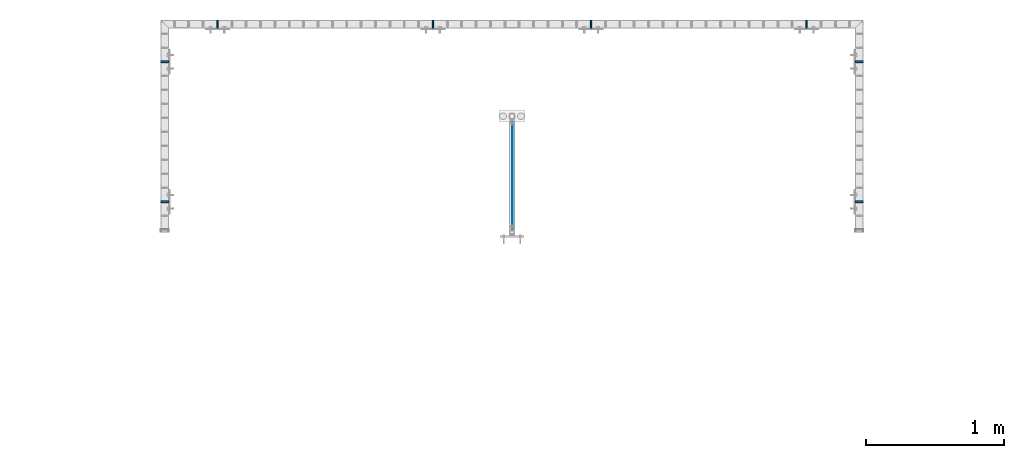
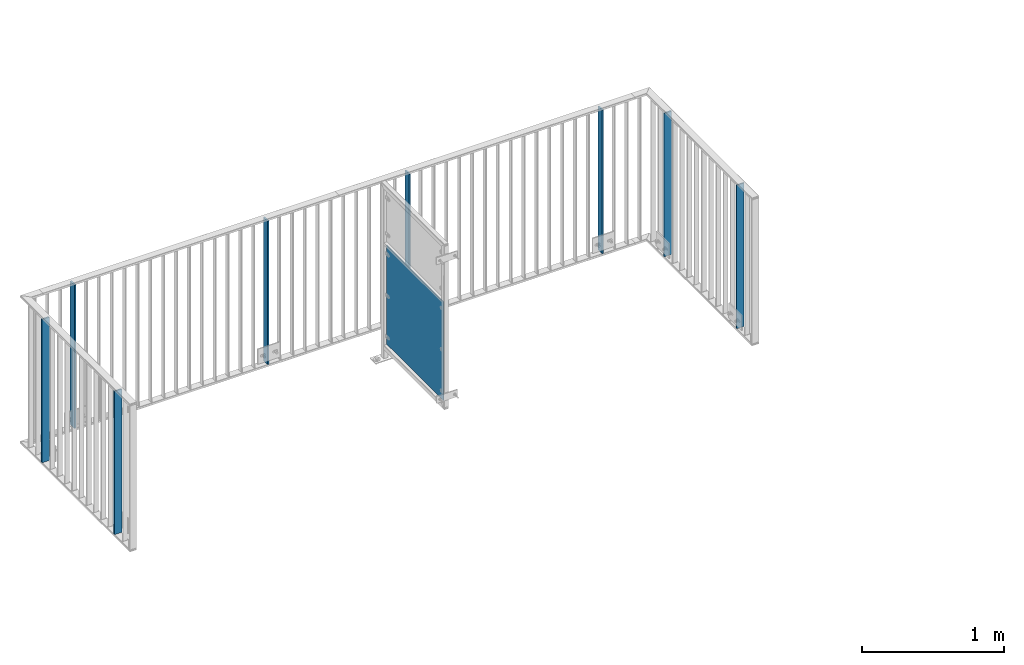
# One storey, part 40 of 156: 9 plates, 5 elements without a shape of their own.
"""IFC2X3 building model written with IfcOpenShell, lengths in millimetres."""

from ifc_helpers import new_model, si_unit, frame, origin_with_axes, origin_2d_with_axis, place, context, subcontext, project, spatial, rectangle, extrude, material, type_object, element, aggregate, save


model = new_model("IFC2X3")

# Units and contexts
model_context = context("Model", 3, precision=1e-05, world=origin_with_axes())
body_context = subcontext(model_context, "Body", "Model", "MODEL_VIEW")
ifc_project = project(units=[si_unit("LENGTHUNIT", "METRE", prefix="MILLI"), si_unit("AREAUNIT", "SQUARE_METRE"), si_unit("VOLUMEUNIT", "CUBIC_METRE"), si_unit("MASSUNIT", "GRAM", prefix="KILO"), si_unit("TIMEUNIT", "SECOND"), si_unit("PLANEANGLEUNIT", "RADIAN"), si_unit("SOLIDANGLEUNIT", "STERADIAN"), si_unit("THERMODYNAMICTEMPERATUREUNIT", "DEGREE_CELSIUS"), si_unit("LUMINOUSINTENSITYUNIT", "LUMEN")], contexts=[model_context])

# Site, building, storey
site_placement = place(None, origin_with_axes())
site = spatial("IfcSite", under=ifc_project, at=site_placement, CompositionType="ELEMENT")
building_placement = place(site_placement, origin_with_axes())
building = spatial("IfcBuilding", under=site, at=building_placement, Name="Undefined", CompositionType="ELEMENT")
storey_placement = place(building_placement, origin_with_axes())
storey = spatial("IfcBuildingStorey", under=building, at=storey_placement, Name="Undefined", CompositionType="ELEMENT", Elevation=0.0)

# Assembly, plates
assembly_1_placement = place(storey_placement, origin_with_axes())
assembly_1 = element("IfcElementAssembly", 1, at=assembly_1_placement, inside=storey, AssemblyPlace="NOTDEFINED", PredefinedType="RIGID_FRAME")
ifc_material = material(Name="STEEL/S235JR")
plate_type_1 = type_object("IfcPlateType", PredefinedType="NOTDEFINED")
plate_1_placement = place(assembly_1_placement, frame((17325.0016407503, 22766.5810137578, 3980.00000000003), z_axis=(-1.0, 0.0, 0.0), x_axis=(0.0, 0.0, -1.0)))
plate_1 = element("IfcPlate", 2, at=plate_1_placement, type_object=plate_type_1, material=ifc_material, context=body_context, shape_type="SweptSolid", body=[
    extrude(rectangle(XDim=12.0, YDim=60.0, at=origin_2d_with_axis()), frame((1230.0, 0.0, 0.0), z_axis=(-1.0, 0.0, 0.0), x_axis=(0.0, -1.0, 0.0)), (0.0, 0.0, 1.0), 1230.0),
])
plate_2_placement = place(assembly_1_placement, frame((17325.0016407503, 23784.4303835178, 3980.00000000003), z_axis=(-1.0, 0.0, 0.0), x_axis=(0.0, 0.0, -1.0)))
plate_2 = element("IfcPlate", 3, at=plate_2_placement, type_object=plate_type_1, material=ifc_material, context=body_context, shape_type="SweptSolid", body=[
    extrude(rectangle(XDim=12.0, YDim=60.0, at=origin_2d_with_axis()), frame((1230.0, 0.0, 0.0), z_axis=(-1.0, 0.0, 0.0), x_axis=(0.0, -1.0, 0.0)), (0.0, 0.0, 1.0), 1230.0),
])
aggregate(assembly_1, [plate_1, plate_2])

# Assembly, plate
assembly_2_placement = place(storey_placement, origin_with_axes())
assembly_2 = element("IfcElementAssembly", 4, at=assembly_2_placement, inside=storey, AssemblyPlace="NOTDEFINED", PredefinedType="RIGID_FRAME")
plate_3_placement = place(assembly_2_placement, frame((12274.9983592497, 22766.5810137578, 3980.00000000003), z_axis=(1.0, 0.0, 0.0), x_axis=(0.0, 0.0, -1.0)))
plate_3 = element("IfcPlate", 5, at=plate_3_placement, type_object=plate_type_1, material=ifc_material, context=body_context, shape_type="SweptSolid", body=[
    extrude(rectangle(XDim=12.0, YDim=60.0, at=origin_2d_with_axis()), frame((1230.0, 0.0, 0.0), z_axis=(-1.0, 0.0, 0.0), x_axis=(0.0, -1.0, 0.0)), (0.0, 0.0, 1.0), 1230.0),
])

assembly_3_placement = place(storey_placement, origin_with_axes())
assembly_3 = element("IfcElementAssembly", 6, at=assembly_3_placement, inside=storey, AssemblyPlace="NOTDEFINED", PredefinedType="RIGID_FRAME")
plate_4_placement = place(assembly_3_placement, frame((15374.6454415188, 24057.9916060596, 3980.00000000003), z_axis=(0.0, -1.0, 0.0), x_axis=(0.0, 0.0, -1.0)))
plate_4 = element("IfcPlate", 7, at=plate_4_placement, type_object=plate_type_1, material=ifc_material, context=body_context, shape_type="SweptSolid", body=[
    extrude(rectangle(XDim=12.0, YDim=60.0, at=origin_2d_with_axis()), frame((1230.0, 0.0, 0.0), z_axis=(-1.0, 0.0, 0.0), x_axis=(0.0, -1.0, 0.0)), (0.0, 0.0, 1.0), 1230.0),
])

# Assembly, plates
assembly_4_placement = place(storey_placement, origin_with_axes())
assembly_4 = element("IfcElementAssembly", 8, at=assembly_4_placement, inside=storey, AssemblyPlace="NOTDEFINED", PredefinedType="RIGID_FRAME")
plate_5_placement = place(assembly_4_placement, frame((14225.3401831972, 24057.9916060596, 3980.00000000003), z_axis=(0.0, -1.0, 0.0), x_axis=(0.0, 0.0, -1.0)))
plate_5 = element("IfcPlate", 9, at=plate_5_placement, type_object=plate_type_1, material=ifc_material, context=body_context, shape_type="SweptSolid", body=[
    extrude(rectangle(XDim=12.0, YDim=60.0, at=origin_2d_with_axis()), frame((1230.0, 0.0, 0.0), z_axis=(-1.0, 0.0, 0.0), x_axis=(0.0, -1.0, 0.0)), (0.0, 0.0, 1.0), 1230.0),
])
plate_6_placement = place(assembly_4_placement, frame((12658.3187312877, 24057.9916060596, 3980.00000000003), z_axis=(0.0, -1.0, 0.0), x_axis=(0.0, 0.0, -1.0)))
plate_6 = element("IfcPlate", 10, at=plate_6_placement, type_object=plate_type_1, material=ifc_material, context=body_context, shape_type="SweptSolid", body=[
    extrude(rectangle(XDim=12.0, YDim=60.0, at=origin_2d_with_axis()), frame((1230.0, 0.0, 0.0), z_axis=(-1.0, 0.0, 0.0), x_axis=(0.0, -1.0, 0.0)), (0.0, 0.0, 1.0), 1230.0),
])
aggregate(assembly_4, [plate_5, plate_6])

# Plate
plate_7_placement = place(assembly_3_placement, frame((16941.6668934283, 24057.9916060596, 3980.00000000003), z_axis=(0.0, -1.0, 0.0), x_axis=(0.0, 0.0, -1.0)))
plate_7 = element("IfcPlate", 11, at=plate_7_placement, type_object=plate_type_1, material=ifc_material, context=body_context, shape_type="SweptSolid", body=[
    extrude(rectangle(XDim=12.0, YDim=60.0, at=origin_2d_with_axis()), frame((1230.0, 0.0, 0.0), z_axis=(-1.0, 0.0, 0.0), x_axis=(0.0, -1.0, 0.0)), (0.0, 0.0, 1.0), 1230.0),
])

aggregate(assembly_3, [plate_4, plate_7])

plate_8_placement = place(assembly_2_placement, frame((12274.9983592497, 23784.4303835178, 3980.00000000003), z_axis=(1.0, 0.0, 0.0), x_axis=(0.0, 0.0, -1.0)))
plate_8 = element("IfcPlate", 12, at=plate_8_placement, type_object=plate_type_1, material=ifc_material, context=body_context, shape_type="SweptSolid", body=[
    extrude(rectangle(XDim=12.0, YDim=60.0, at=origin_2d_with_axis()), frame((1230.0, 0.0, 0.0), z_axis=(-1.0, 0.0, 0.0), x_axis=(0.0, -1.0, 0.0)), (0.0, 0.0, 1.0), 1230.0),
])

aggregate(assembly_2, [plate_3, plate_8])

# Assembly, plate
assembly_5_placement = place(storey_placement, origin_with_axes())
assembly_5 = element("IfcElementAssembly", 13, at=assembly_5_placement, inside=storey, AssemblyPlace="NOTDEFINED", PredefinedType="RIGID_FRAME")
plate_type_2 = type_object("IfcPlateType", PredefinedType="NOTDEFINED")
plate_9_placement = place(assembly_5_placement, frame((14804.0, 22562.9559575678, 3550.0), z_axis=(0.0, 0.0, 1.0), x_axis=(0.0, 1.0, 0.0)))
plate_9 = element("IfcPlate", 14, at=plate_9_placement, type_object=plate_type_2, material=ifc_material, context=body_context, shape_type="SweptSolid", body=[
    extrude(rectangle(XDim=3.0, YDim=850.0, at=origin_2d_with_axis()), frame((800.050991195178, 0.0, 0.0), z_axis=(-1.0, 0.0, 0.0), x_axis=(0.0, -1.0, 0.0)), (0.0, 0.0, 1.0), 800.05),
])
aggregate(assembly_5, [plate_9])

save(model, "model.ifc")
